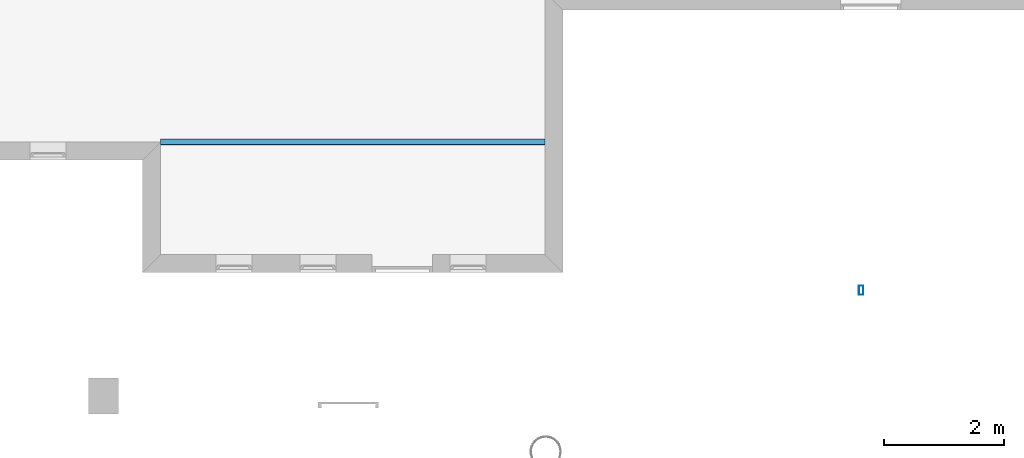
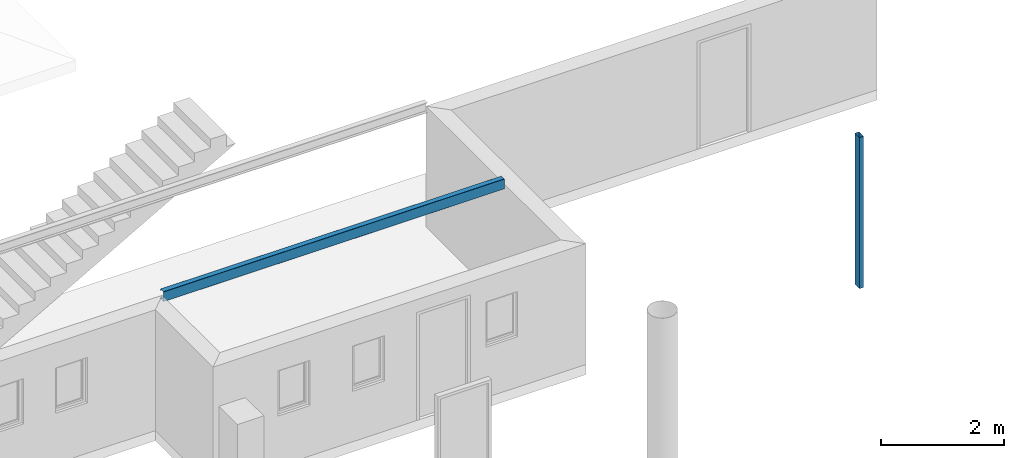
# One storey, part 2 of 5: 1 beam, 1 column.
"""IFC4 building model written with IfcOpenShell, lengths in millimetres."""

from ifc_helpers import new_model, entity, si_unit, converted_unit, frame, origin_with_axes, origin_2d_with_axis, place, context, subcontext, project, spatial, hollow_rectangle, c_section, extrude, material, material_profile, profile_set, profile_usage, type_object, element, save


model = new_model("IFC4")

# Units and contexts
model_context = context("Model", 3, precision=1e-05, world=origin_with_axes())
plan_context = context("Plan", 2, precision=1e-05, world=origin_2d_with_axis())
body_context = subcontext(model_context, "Body", "Model", "MODEL_VIEW")
ifc_project = project(units=[si_unit("VOLUMEUNIT", "CUBIC_METRE"), si_unit("LENGTHUNIT", "METRE", prefix="MILLI"), converted_unit("PLANEANGLEUNIT", "degree", entity("IfcReal", 0.0174532925199433), si_unit("PLANEANGLEUNIT", "RADIAN"), dimensions=[0, 0, 0, 0, 0, 0, 0]), si_unit("AREAUNIT", "SQUARE_METRE")], contexts=[model_context, plan_context])

# Site, building, storey
site_placement = place(None, origin_with_axes())
site = spatial("IfcSite", under=ifc_project, at=site_placement)
building_placement = place(site_placement, origin_with_axes())
building = spatial("IfcBuilding", under=site, at=building_placement, Name="Building")
storey_placement = place(building_placement, origin_with_axes())
storey = spatial("IfcBuildingStorey", under=building, at=storey_placement, Name="Storey")

# Column
ifc_material = material()
ifc_material_profile_1 = material_profile(ifc_material, hollow_rectangle(XDim=75.0, YDim=150.0, WallThickness=2.0, InnerFilletRadius=5.0, OuterFilletRadius=5.0))
ifc_profile_set_1 = profile_set([ifc_material_profile_1])
ifc_profile_usage_1 = profile_usage(ifc_profile_set_1)
column_type = type_object("IfcColumnType", Name="C3", PredefinedType="NOTDEFINED", material=ifc_profile_set_1)
column_placement = place(storey_placement, frame((14347.7325439453, -6290.07625579834, 0.0), z_axis=(0.0, 0.0, 1.0), x_axis=(1.0, 0.0, 0.0)))
element("IfcColumn", 1, at=column_placement, inside=storey, type_object=column_type, material=ifc_profile_usage_1, Name="Column", context=body_context, shape_type="SweptSolid", body=[
    extrude(hollow_rectangle(XDim=75.0, YDim=150.0, WallThickness=2.0, InnerFilletRadius=5.0, OuterFilletRadius=5.0), origin_with_axes(), (0.0, 0.0, 1.0), 3000.0),
])

# Beam
ifc_material_profile_2 = material_profile(ifc_material, c_section(Depth=200.0, Width=100.0, WallThickness=1.5, Girth=30.0, InternalFilletRadius=5.0))
ifc_profile_set_2 = profile_set([ifc_material_profile_2])
ifc_profile_usage_2 = profile_usage(ifc_profile_set_2, cardinal=5)
beam_type = type_object("IfcBeamType", Name="B2", PredefinedType="NOTDEFINED", material=ifc_profile_set_2)
beam_placement = place(storey_placement, frame((2678.67970466614, -3821.32029533386, 2400.00009536743), z_axis=(0.999999999999695, -5.5233481006622e-07, 5.52335037439936e-07), x_axis=(5.52335037439972e-07, 0.99999999999976, -4.17232502769491e-07)))
element("IfcBeam", 2, at=beam_placement, inside=storey, type_object=beam_type, material=ifc_profile_usage_2, Name="Beam", context=body_context, shape_type="SweptSolid", body=[
    extrude(c_section(Depth=200.0, Width=100.0, WallThickness=1.5, Girth=30.0, InternalFilletRadius=5.0), origin_with_axes(), (0.0, 0.0, 1.0), 6399.93376697602),
])

save(model, "model.ifc")
